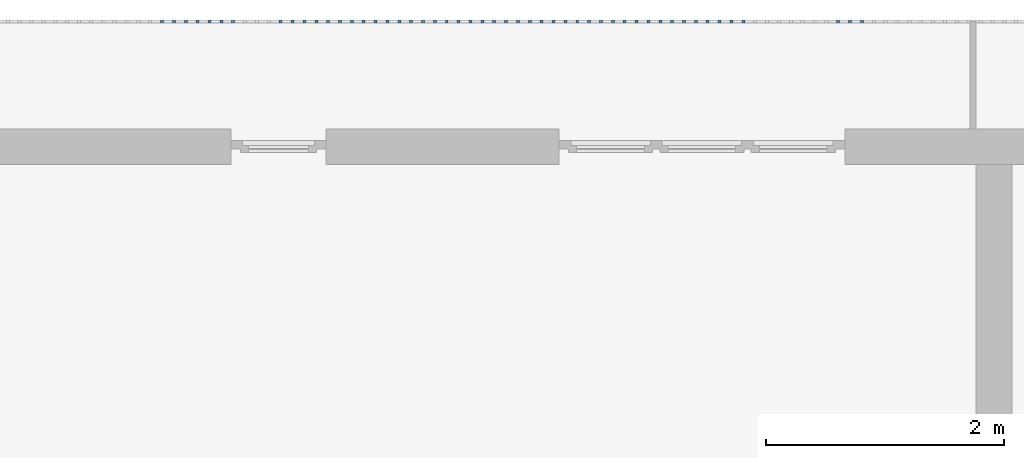
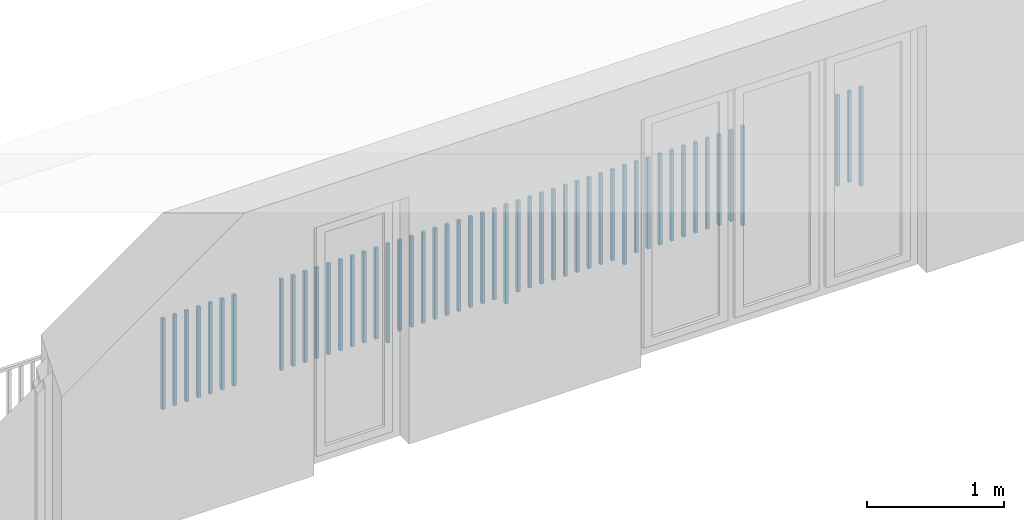
# One storey, part 43 of 48: 50 building element parts, 1 element without a shape of its own.
"""IFC4 building model written with IfcOpenShell, lengths in metres."""

from ifc_helpers import new_model, entity, si_unit, converted_unit, derived_unit, direction, frame, origin_with_axes, place, context, subcontext, project, spatial, polygons, material, type_object, element, aggregate, save


model = new_model("IFC4")

# Units and contexts
model_context = context("Model", 3, precision=1e-05, world=origin_with_axes(), true_north=direction((0.0, 1.0)))
body_context = subcontext(model_context, "Body", "Model", "MODEL_VIEW")
ifc_project = project(units=[si_unit("LENGTHUNIT", "METRE"), si_unit("AREAUNIT", "SQUARE_METRE"), si_unit("VOLUMEUNIT", "CUBIC_METRE"), converted_unit("PLANEANGLEUNIT", "DEGREE", entity("IfcPlaneAngleMeasure", 0.0174532925199), si_unit("PLANEANGLEUNIT", "RADIAN"), dimensions=[0, 0, 0, 0, 0, 0, 0]), converted_unit("TIMEUNIT", "Year", entity("IfcTimeMeasure", 31556926.0), si_unit("TIMEUNIT", "SECOND"), dimensions=[0, 0, 1, 0, 0, 0, 0]), si_unit("MASSUNIT", "GRAM", prefix="KILO"), si_unit("THERMODYNAMICTEMPERATUREUNIT", "DEGREE_CELSIUS"), si_unit("LUMINOUSINTENSITYUNIT", "LUMEN"), si_unit("ENERGYUNIT", "JOULE", prefix="MEGA"), derived_unit("THERMALCONDUCTANCEUNIT", [(si_unit("POWERUNIT", "WATT"), 1), (si_unit("LENGTHUNIT", "METRE"), -1), (si_unit("THERMODYNAMICTEMPERATUREUNIT", "KELVIN"), -1)]), derived_unit("SPECIFICHEATCAPACITYUNIT", [(si_unit("ENERGYUNIT", "JOULE"), 1), (si_unit("MASSUNIT", "GRAM", prefix="KILO"), -1), (si_unit("THERMODYNAMICTEMPERATUREUNIT", "KELVIN"), -1)]), derived_unit("MASSDENSITYUNIT", [(si_unit("MASSUNIT", "GRAM", prefix="KILO"), 1), (si_unit("VOLUMEUNIT", "CUBIC_METRE"), -1)])], contexts=[model_context])

# Site, building, storey
site_placement = place(None, origin_with_axes())
site = spatial("IfcSite", under=ifc_project, at=site_placement, CompositionType="ELEMENT")
building_placement = place(site_placement, origin_with_axes())
building = spatial("IfcBuilding", under=site, at=building_placement, CompositionType="ELEMENT")
storey_placement = place(building_placement, frame((0.0, 0.0, 3.4), z_axis=(0.0, 0.0, 1.0), x_axis=(1.0, 0.0, 0.0)))
storey = spatial("IfcBuildingStorey", under=building, at=storey_placement, Name="1. Geschoss", CompositionType="ELEMENT", Elevation=3.4)

# Railing, building element parts
railing_type = type_object("IfcRailingType", PredefinedType="NOTDEFINED")
railing_placement = place(storey_placement, frame((10.2378006196, 9.82118776896, 0.0), z_axis=(0.0, 0.0, 1.0), x_axis=(1.0, 0.0, 0.0)))
railing = element("IfcRailing", 1, at=railing_placement, inside=storey, type_object=railing_type, PredefinedType="NOTDEFINED")
ifc_material = material()
building_element_part_1_placement = place(railing_placement, origin_with_axes())
building_element_part_1 = element("IfcBuildingElementPart", 2, at=building_element_part_1_placement, material=ifc_material, PredefinedType="NOTDEFINED", context=body_context, shape_type="Tessellation", body=[
    polygons([(-11.9498913043, 0.0125, 0.0), (-11.9498913043, -0.0125, 0.0), (-11.9498913043, -0.0125, 0.88), (-11.9498913043, 0.0125, 0.88), (-11.9248913043, 0.0125, 0.0), (-11.9248913043, -0.0125, 0.0), (-11.9248913043, -0.0125, 0.88), (-11.9248913043, 0.0125, 0.88)], [[[1, 2, 3, 4]], [[1, 5, 6, 2]], [[2, 6, 7, 3]], [[4, 3, 7, 8]], [[5, 1, 4, 8]], [[6, 5, 8, 7]]], closed=True),
])
building_element_part_2_placement = place(railing_placement, origin_with_axes())
building_element_part_2 = element("IfcBuildingElementPart", 3, at=building_element_part_2_placement, material=ifc_material, PredefinedType="NOTDEFINED", context=body_context, shape_type="Tessellation", body=[
    polygons([(-12.0493695652, 0.0125, 0.07), (-12.0493695652, -0.0125, 0.07), (-12.0493695652, -0.0125, 0.8775), (-12.0493695652, 0.0125, 0.8775), (-12.0243695652, 0.0125, 0.07), (-12.0243695652, -0.0125, 0.07), (-12.0243695652, -0.0125, 0.8775), (-12.0243695652, 0.0125, 0.8775)], [[[1, 2, 3, 4]], [[1, 5, 6, 2]], [[2, 6, 7, 3]], [[4, 3, 7, 8]], [[5, 1, 4, 8]], [[6, 5, 8, 7]]], closed=True),
])
building_element_part_3_placement = place(railing_placement, origin_with_axes())
building_element_part_3 = element("IfcBuildingElementPart", 4, at=building_element_part_3_placement, material=ifc_material, PredefinedType="NOTDEFINED", context=body_context, shape_type="Tessellation", body=[
    polygons([(-12.1488478261, 0.0125, 0.07), (-12.1488478261, -0.0125, 0.07), (-12.1488478261, -0.0125, 0.8775), (-12.1488478261, 0.0125, 0.8775), (-12.1238478261, 0.0125, 0.07), (-12.1238478261, -0.0125, 0.07), (-12.1238478261, -0.0125, 0.8775), (-12.1238478261, 0.0125, 0.8775)], [[[1, 2, 3, 4]], [[1, 5, 6, 2]], [[2, 6, 7, 3]], [[4, 3, 7, 8]], [[5, 1, 4, 8]], [[6, 5, 8, 7]]], closed=True),
])
building_element_part_4_placement = place(railing_placement, origin_with_axes())
building_element_part_4 = element("IfcBuildingElementPart", 5, at=building_element_part_4_placement, material=ifc_material, PredefinedType="NOTDEFINED", context=body_context, shape_type="Tessellation", body=[
    polygons([(-12.944673913, 0.0125, 0.0), (-12.944673913, -0.0125, 0.0), (-12.944673913, -0.0125, 0.88), (-12.944673913, 0.0125, 0.88), (-12.919673913, 0.0125, 0.0), (-12.919673913, -0.0125, 0.0), (-12.919673913, -0.0125, 0.88), (-12.919673913, 0.0125, 0.88)], [[[1, 2, 3, 4]], [[1, 5, 6, 2]], [[2, 6, 7, 3]], [[4, 3, 7, 8]], [[5, 1, 4, 8]], [[6, 5, 8, 7]]], closed=True),
])
building_element_part_5_placement = place(railing_placement, origin_with_axes())
building_element_part_5 = element("IfcBuildingElementPart", 6, at=building_element_part_5_placement, material=ifc_material, PredefinedType="NOTDEFINED", context=body_context, shape_type="Tessellation", body=[
    polygons([(-13.0441521739, 0.0125, 0.07), (-13.0441521739, -0.0125, 0.07), (-13.0441521739, -0.0125, 0.8775), (-13.0441521739, 0.0125, 0.8775), (-13.0191521739, 0.0125, 0.07), (-13.0191521739, -0.0125, 0.07), (-13.0191521739, -0.0125, 0.8775), (-13.0191521739, 0.0125, 0.8775)], [[[1, 2, 3, 4]], [[1, 5, 6, 2]], [[2, 6, 7, 3]], [[4, 3, 7, 8]], [[5, 1, 4, 8]], [[6, 5, 8, 7]]], closed=True),
])
building_element_part_6_placement = place(railing_placement, origin_with_axes())
building_element_part_6 = element("IfcBuildingElementPart", 7, at=building_element_part_6_placement, material=ifc_material, PredefinedType="NOTDEFINED", context=body_context, shape_type="Tessellation", body=[
    polygons([(-13.1436304348, 0.0125, 0.07), (-13.1436304348, -0.0125, 0.07), (-13.1436304348, -0.0125, 0.8775), (-13.1436304348, 0.0125, 0.8775), (-13.1186304348, 0.0125, 0.07), (-13.1186304348, -0.0125, 0.07), (-13.1186304348, -0.0125, 0.8775), (-13.1186304348, 0.0125, 0.8775)], [[[1, 2, 3, 4]], [[1, 5, 6, 2]], [[2, 6, 7, 3]], [[4, 3, 7, 8]], [[5, 1, 4, 8]], [[6, 5, 8, 7]]], closed=True),
])
building_element_part_7_placement = place(railing_placement, origin_with_axes())
building_element_part_7 = element("IfcBuildingElementPart", 8, at=building_element_part_7_placement, material=ifc_material, PredefinedType="NOTDEFINED", context=body_context, shape_type="Tessellation", body=[
    polygons([(-13.2431086957, 0.0125, 0.07), (-13.2431086957, -0.0125, 0.07), (-13.2431086957, -0.0125, 0.8775), (-13.2431086957, 0.0125, 0.8775), (-13.2181086957, 0.0125, 0.07), (-13.2181086957, -0.0125, 0.07), (-13.2181086957, -0.0125, 0.8775), (-13.2181086957, 0.0125, 0.8775)], [[[1, 2, 3, 4]], [[1, 5, 6, 2]], [[2, 6, 7, 3]], [[4, 3, 7, 8]], [[5, 1, 4, 8]], [[6, 5, 8, 7]]], closed=True),
])
building_element_part_8_placement = place(railing_placement, origin_with_axes())
building_element_part_8 = element("IfcBuildingElementPart", 9, at=building_element_part_8_placement, material=ifc_material, PredefinedType="NOTDEFINED", context=body_context, shape_type="Tessellation", body=[
    polygons([(-13.3425869565, 0.0125, 0.07), (-13.3425869565, -0.0125, 0.07), (-13.3425869565, -0.0125, 0.8775), (-13.3425869565, 0.0125, 0.8775), (-13.3175869565, 0.0125, 0.07), (-13.3175869565, -0.0125, 0.07), (-13.3175869565, -0.0125, 0.8775), (-13.3175869565, 0.0125, 0.8775)], [[[1, 2, 3, 4]], [[1, 5, 6, 2]], [[2, 6, 7, 3]], [[4, 3, 7, 8]], [[5, 1, 4, 8]], [[6, 5, 8, 7]]], closed=True),
])
building_element_part_9_placement = place(railing_placement, origin_with_axes())
building_element_part_9 = element("IfcBuildingElementPart", 10, at=building_element_part_9_placement, material=ifc_material, PredefinedType="NOTDEFINED", context=body_context, shape_type="Tessellation", body=[
    polygons([(-13.4420652174, 0.0125, 0.07), (-13.4420652174, -0.0125, 0.07), (-13.4420652174, -0.0125, 0.8775), (-13.4420652174, 0.0125, 0.8775), (-13.4170652174, 0.0125, 0.07), (-13.4170652174, -0.0125, 0.07), (-13.4170652174, -0.0125, 0.8775), (-13.4170652174, 0.0125, 0.8775)], [[[1, 2, 3, 4]], [[1, 5, 6, 2]], [[2, 6, 7, 3]], [[4, 3, 7, 8]], [[5, 1, 4, 8]], [[6, 5, 8, 7]]], closed=True),
])
building_element_part_10_placement = place(railing_placement, origin_with_axes())
building_element_part_10 = element("IfcBuildingElementPart", 11, at=building_element_part_10_placement, material=ifc_material, PredefinedType="NOTDEFINED", context=body_context, shape_type="Tessellation", body=[
    polygons([(-13.5415434783, 0.0125, 0.07), (-13.5415434783, -0.0125, 0.07), (-13.5415434783, -0.0125, 0.8775), (-13.5415434783, 0.0125, 0.8775), (-13.5165434783, 0.0125, 0.07), (-13.5165434783, -0.0125, 0.07), (-13.5165434783, -0.0125, 0.8775), (-13.5165434783, 0.0125, 0.8775)], [[[1, 2, 3, 4]], [[1, 5, 6, 2]], [[2, 6, 7, 3]], [[4, 3, 7, 8]], [[5, 1, 4, 8]], [[6, 5, 8, 7]]], closed=True),
])
building_element_part_11_placement = place(railing_placement, origin_with_axes())
building_element_part_11 = element("IfcBuildingElementPart", 12, at=building_element_part_11_placement, material=ifc_material, PredefinedType="NOTDEFINED", context=body_context, shape_type="Tessellation", body=[
    polygons([(-13.6410217391, 0.0125, 0.07), (-13.6410217391, -0.0125, 0.07), (-13.6410217391, -0.0125, 0.8775), (-13.6410217391, 0.0125, 0.8775), (-13.6160217391, 0.0125, 0.07), (-13.6160217391, -0.0125, 0.07), (-13.6160217391, -0.0125, 0.8775), (-13.6160217391, 0.0125, 0.8775)], [[[1, 2, 3, 4]], [[1, 5, 6, 2]], [[2, 6, 7, 3]], [[4, 3, 7, 8]], [[5, 1, 4, 8]], [[6, 5, 8, 7]]], closed=True),
])
building_element_part_12_placement = place(railing_placement, origin_with_axes())
building_element_part_12 = element("IfcBuildingElementPart", 13, at=building_element_part_12_placement, material=ifc_material, PredefinedType="NOTDEFINED", context=body_context, shape_type="Tessellation", body=[
    polygons([(-13.7405, 0.0125, 0.07), (-13.7405, -0.0125, 0.07), (-13.7405, -0.0125, 0.8775), (-13.7405, 0.0125, 0.8775), (-13.7155, 0.0125, 0.07), (-13.7155, -0.0125, 0.07), (-13.7155, -0.0125, 0.8775), (-13.7155, 0.0125, 0.8775)], [[[1, 2, 3, 4]], [[1, 5, 6, 2]], [[2, 6, 7, 3]], [[4, 3, 7, 8]], [[5, 1, 4, 8]], [[6, 5, 8, 7]]], closed=True),
])
building_element_part_13_placement = place(railing_placement, origin_with_axes())
building_element_part_13 = element("IfcBuildingElementPart", 14, at=building_element_part_13_placement, material=ifc_material, PredefinedType="NOTDEFINED", context=body_context, shape_type="Tessellation", body=[
    polygons([(-13.8399782609, 0.0125, 0.07), (-13.8399782609, -0.0125, 0.07), (-13.8399782609, -0.0125, 0.8775), (-13.8399782609, 0.0125, 0.8775), (-13.8149782609, 0.0125, 0.07), (-13.8149782609, -0.0125, 0.07), (-13.8149782609, -0.0125, 0.8775), (-13.8149782609, 0.0125, 0.8775)], [[[1, 2, 3, 4]], [[1, 5, 6, 2]], [[2, 6, 7, 3]], [[4, 3, 7, 8]], [[5, 1, 4, 8]], [[6, 5, 8, 7]]], closed=True),
])
building_element_part_14_placement = place(railing_placement, origin_with_axes())
building_element_part_14 = element("IfcBuildingElementPart", 15, at=building_element_part_14_placement, material=ifc_material, PredefinedType="NOTDEFINED", context=body_context, shape_type="Tessellation", body=[
    polygons([(-13.9394565217, 0.0125, 0.0), (-13.9394565217, -0.0125, 0.0), (-13.9394565217, -0.0125, 0.88), (-13.9394565217, 0.0125, 0.88), (-13.9144565217, 0.0125, 0.0), (-13.9144565217, -0.0125, 0.0), (-13.9144565217, -0.0125, 0.88), (-13.9144565217, 0.0125, 0.88)], [[[1, 2, 3, 4]], [[1, 5, 6, 2]], [[2, 6, 7, 3]], [[4, 3, 7, 8]], [[5, 1, 4, 8]], [[6, 5, 8, 7]]], closed=True),
])
building_element_part_15_placement = place(railing_placement, origin_with_axes())
building_element_part_15 = element("IfcBuildingElementPart", 16, at=building_element_part_15_placement, material=ifc_material, PredefinedType="NOTDEFINED", context=body_context, shape_type="Tessellation", body=[
    polygons([(-14.0389347826, 0.0125, 0.07), (-14.0389347826, -0.0125, 0.07), (-14.0389347826, -0.0125, 0.8775), (-14.0389347826, 0.0125, 0.8775), (-14.0139347826, 0.0125, 0.07), (-14.0139347826, -0.0125, 0.07), (-14.0139347826, -0.0125, 0.8775), (-14.0139347826, 0.0125, 0.8775)], [[[1, 2, 3, 4]], [[1, 5, 6, 2]], [[2, 6, 7, 3]], [[4, 3, 7, 8]], [[5, 1, 4, 8]], [[6, 5, 8, 7]]], closed=True),
])
building_element_part_16_placement = place(railing_placement, origin_with_axes())
building_element_part_16 = element("IfcBuildingElementPart", 17, at=building_element_part_16_placement, material=ifc_material, PredefinedType="NOTDEFINED", context=body_context, shape_type="Tessellation", body=[
    polygons([(-14.1384130435, 0.0125, 0.07), (-14.1384130435, -0.0125, 0.07), (-14.1384130435, -0.0125, 0.8775), (-14.1384130435, 0.0125, 0.8775), (-14.1134130435, 0.0125, 0.07), (-14.1134130435, -0.0125, 0.07), (-14.1134130435, -0.0125, 0.8775), (-14.1134130435, 0.0125, 0.8775)], [[[1, 2, 3, 4]], [[1, 5, 6, 2]], [[2, 6, 7, 3]], [[4, 3, 7, 8]], [[5, 1, 4, 8]], [[6, 5, 8, 7]]], closed=True),
])
building_element_part_17_placement = place(railing_placement, origin_with_axes())
building_element_part_17 = element("IfcBuildingElementPart", 18, at=building_element_part_17_placement, material=ifc_material, PredefinedType="NOTDEFINED", context=body_context, shape_type="Tessellation", body=[
    polygons([(-14.2378913043, 0.0125, 0.07), (-14.2378913043, -0.0125, 0.07), (-14.2378913043, -0.0125, 0.8775), (-14.2378913043, 0.0125, 0.8775), (-14.2128913043, 0.0125, 0.07), (-14.2128913043, -0.0125, 0.07), (-14.2128913043, -0.0125, 0.8775), (-14.2128913043, 0.0125, 0.8775)], [[[1, 2, 3, 4]], [[1, 5, 6, 2]], [[2, 6, 7, 3]], [[4, 3, 7, 8]], [[5, 1, 4, 8]], [[6, 5, 8, 7]]], closed=True),
])
building_element_part_18_placement = place(railing_placement, origin_with_axes())
building_element_part_18 = element("IfcBuildingElementPart", 19, at=building_element_part_18_placement, material=ifc_material, PredefinedType="NOTDEFINED", context=body_context, shape_type="Tessellation", body=[
    polygons([(-14.3373695652, 0.0125, 0.07), (-14.3373695652, -0.0125, 0.07), (-14.3373695652, -0.0125, 0.8775), (-14.3373695652, 0.0125, 0.8775), (-14.3123695652, 0.0125, 0.07), (-14.3123695652, -0.0125, 0.07), (-14.3123695652, -0.0125, 0.8775), (-14.3123695652, 0.0125, 0.8775)], [[[1, 2, 3, 4]], [[1, 5, 6, 2]], [[2, 6, 7, 3]], [[4, 3, 7, 8]], [[5, 1, 4, 8]], [[6, 5, 8, 7]]], closed=True),
])
building_element_part_19_placement = place(railing_placement, origin_with_axes())
building_element_part_19 = element("IfcBuildingElementPart", 20, at=building_element_part_19_placement, material=ifc_material, PredefinedType="NOTDEFINED", context=body_context, shape_type="Tessellation", body=[
    polygons([(-14.4368478261, 0.0125, 0.07), (-14.4368478261, -0.0125, 0.07), (-14.4368478261, -0.0125, 0.8775), (-14.4368478261, 0.0125, 0.8775), (-14.4118478261, 0.0125, 0.07), (-14.4118478261, -0.0125, 0.07), (-14.4118478261, -0.0125, 0.8775), (-14.4118478261, 0.0125, 0.8775)], [[[1, 2, 3, 4]], [[1, 5, 6, 2]], [[2, 6, 7, 3]], [[4, 3, 7, 8]], [[5, 1, 4, 8]], [[6, 5, 8, 7]]], closed=True),
])
building_element_part_20_placement = place(railing_placement, origin_with_axes())
building_element_part_20 = element("IfcBuildingElementPart", 21, at=building_element_part_20_placement, material=ifc_material, PredefinedType="NOTDEFINED", context=body_context, shape_type="Tessellation", body=[
    polygons([(-14.536326087, 0.0125, 0.07), (-14.536326087, -0.0125, 0.07), (-14.536326087, -0.0125, 0.8775), (-14.536326087, 0.0125, 0.8775), (-14.511326087, 0.0125, 0.07), (-14.511326087, -0.0125, 0.07), (-14.511326087, -0.0125, 0.8775), (-14.511326087, 0.0125, 0.8775)], [[[1, 2, 3, 4]], [[1, 5, 6, 2]], [[2, 6, 7, 3]], [[4, 3, 7, 8]], [[5, 1, 4, 8]], [[6, 5, 8, 7]]], closed=True),
])
building_element_part_21_placement = place(railing_placement, origin_with_axes())
building_element_part_21 = element("IfcBuildingElementPart", 22, at=building_element_part_21_placement, material=ifc_material, PredefinedType="NOTDEFINED", context=body_context, shape_type="Tessellation", body=[
    polygons([(-14.6358043478, 0.0125, 0.07), (-14.6358043478, -0.0125, 0.07), (-14.6358043478, -0.0125, 0.8775), (-14.6358043478, 0.0125, 0.8775), (-14.6108043478, 0.0125, 0.07), (-14.6108043478, -0.0125, 0.07), (-14.6108043478, -0.0125, 0.8775), (-14.6108043478, 0.0125, 0.8775)], [[[1, 2, 3, 4]], [[1, 5, 6, 2]], [[2, 6, 7, 3]], [[4, 3, 7, 8]], [[5, 1, 4, 8]], [[6, 5, 8, 7]]], closed=True),
])
building_element_part_22_placement = place(railing_placement, origin_with_axes())
building_element_part_22 = element("IfcBuildingElementPart", 23, at=building_element_part_22_placement, material=ifc_material, PredefinedType="NOTDEFINED", context=body_context, shape_type="Tessellation", body=[
    polygons([(-14.7352826087, 0.0125, 0.07), (-14.7352826087, -0.0125, 0.07), (-14.7352826087, -0.0125, 0.8775), (-14.7352826087, 0.0125, 0.8775), (-14.7102826087, 0.0125, 0.07), (-14.7102826087, -0.0125, 0.07), (-14.7102826087, -0.0125, 0.8775), (-14.7102826087, 0.0125, 0.8775)], [[[1, 2, 3, 4]], [[1, 5, 6, 2]], [[2, 6, 7, 3]], [[4, 3, 7, 8]], [[5, 1, 4, 8]], [[6, 5, 8, 7]]], closed=True),
])
building_element_part_23_placement = place(railing_placement, origin_with_axes())
building_element_part_23 = element("IfcBuildingElementPart", 24, at=building_element_part_23_placement, material=ifc_material, PredefinedType="NOTDEFINED", context=body_context, shape_type="Tessellation", body=[
    polygons([(-14.8347608696, 0.0125, 0.07), (-14.8347608696, -0.0125, 0.07), (-14.8347608696, -0.0125, 0.8775), (-14.8347608696, 0.0125, 0.8775), (-14.8097608696, 0.0125, 0.07), (-14.8097608696, -0.0125, 0.07), (-14.8097608696, -0.0125, 0.8775), (-14.8097608696, 0.0125, 0.8775)], [[[1, 2, 3, 4]], [[1, 5, 6, 2]], [[2, 6, 7, 3]], [[4, 3, 7, 8]], [[5, 1, 4, 8]], [[6, 5, 8, 7]]], closed=True),
])
building_element_part_24_placement = place(railing_placement, origin_with_axes())
building_element_part_24 = element("IfcBuildingElementPart", 25, at=building_element_part_24_placement, material=ifc_material, PredefinedType="NOTDEFINED", context=body_context, shape_type="Tessellation", body=[
    polygons([(-14.9342391304, 0.0125, 0.0), (-14.9342391304, -0.0125, 0.0), (-14.9342391304, -0.0125, 0.88), (-14.9342391304, 0.0125, 0.88), (-14.9092391304, 0.0125, 0.0), (-14.9092391304, -0.0125, 0.0), (-14.9092391304, -0.0125, 0.88), (-14.9092391304, 0.0125, 0.88)], [[[1, 2, 3, 4]], [[1, 5, 6, 2]], [[2, 6, 7, 3]], [[4, 3, 7, 8]], [[5, 1, 4, 8]], [[6, 5, 8, 7]]], closed=True),
])
building_element_part_25_placement = place(railing_placement, origin_with_axes())
building_element_part_25 = element("IfcBuildingElementPart", 26, at=building_element_part_25_placement, material=ifc_material, PredefinedType="NOTDEFINED", context=body_context, shape_type="Tessellation", body=[
    polygons([(-15.0337173913, 0.0125, 0.07), (-15.0337173913, -0.0125, 0.07), (-15.0337173913, -0.0125, 0.8775), (-15.0337173913, 0.0125, 0.8775), (-15.0087173913, 0.0125, 0.07), (-15.0087173913, -0.0125, 0.07), (-15.0087173913, -0.0125, 0.8775), (-15.0087173913, 0.0125, 0.8775)], [[[1, 2, 3, 4]], [[1, 5, 6, 2]], [[2, 6, 7, 3]], [[4, 3, 7, 8]], [[5, 1, 4, 8]], [[6, 5, 8, 7]]], closed=True),
])
building_element_part_26_placement = place(railing_placement, origin_with_axes())
building_element_part_26 = element("IfcBuildingElementPart", 27, at=building_element_part_26_placement, material=ifc_material, PredefinedType="NOTDEFINED", context=body_context, shape_type="Tessellation", body=[
    polygons([(-15.1331956522, 0.0125, 0.07), (-15.1331956522, -0.0125, 0.07), (-15.1331956522, -0.0125, 0.8775), (-15.1331956522, 0.0125, 0.8775), (-15.1081956522, 0.0125, 0.07), (-15.1081956522, -0.0125, 0.07), (-15.1081956522, -0.0125, 0.8775), (-15.1081956522, 0.0125, 0.8775)], [[[1, 2, 3, 4]], [[1, 5, 6, 2]], [[2, 6, 7, 3]], [[4, 3, 7, 8]], [[5, 1, 4, 8]], [[6, 5, 8, 7]]], closed=True),
])
building_element_part_27_placement = place(railing_placement, origin_with_axes())
building_element_part_27 = element("IfcBuildingElementPart", 28, at=building_element_part_27_placement, material=ifc_material, PredefinedType="NOTDEFINED", context=body_context, shape_type="Tessellation", body=[
    polygons([(-15.232673913, 0.0125, 0.07), (-15.232673913, -0.0125, 0.07), (-15.232673913, -0.0125, 0.8775), (-15.232673913, 0.0125, 0.8775), (-15.207673913, 0.0125, 0.07), (-15.207673913, -0.0125, 0.07), (-15.207673913, -0.0125, 0.8775), (-15.207673913, 0.0125, 0.8775)], [[[1, 2, 3, 4]], [[1, 5, 6, 2]], [[2, 6, 7, 3]], [[4, 3, 7, 8]], [[5, 1, 4, 8]], [[6, 5, 8, 7]]], closed=True),
])
building_element_part_28_placement = place(railing_placement, origin_with_axes())
building_element_part_28 = element("IfcBuildingElementPart", 29, at=building_element_part_28_placement, material=ifc_material, PredefinedType="NOTDEFINED", context=body_context, shape_type="Tessellation", body=[
    polygons([(-15.3321521739, 0.0125, 0.07), (-15.3321521739, -0.0125, 0.07), (-15.3321521739, -0.0125, 0.8775), (-15.3321521739, 0.0125, 0.8775), (-15.3071521739, 0.0125, 0.07), (-15.3071521739, -0.0125, 0.07), (-15.3071521739, -0.0125, 0.8775), (-15.3071521739, 0.0125, 0.8775)], [[[1, 2, 3, 4]], [[1, 5, 6, 2]], [[2, 6, 7, 3]], [[4, 3, 7, 8]], [[5, 1, 4, 8]], [[6, 5, 8, 7]]], closed=True),
])
building_element_part_29_placement = place(railing_placement, origin_with_axes())
building_element_part_29 = element("IfcBuildingElementPart", 30, at=building_element_part_29_placement, material=ifc_material, PredefinedType="NOTDEFINED", context=body_context, shape_type="Tessellation", body=[
    polygons([(-15.4316304348, 0.0125, 0.07), (-15.4316304348, -0.0125, 0.07), (-15.4316304348, -0.0125, 0.8775), (-15.4316304348, 0.0125, 0.8775), (-15.4066304348, 0.0125, 0.07), (-15.4066304348, -0.0125, 0.07), (-15.4066304348, -0.0125, 0.8775), (-15.4066304348, 0.0125, 0.8775)], [[[1, 2, 3, 4]], [[1, 5, 6, 2]], [[2, 6, 7, 3]], [[4, 3, 7, 8]], [[5, 1, 4, 8]], [[6, 5, 8, 7]]], closed=True),
])
building_element_part_30_placement = place(railing_placement, origin_with_axes())
building_element_part_30 = element("IfcBuildingElementPart", 31, at=building_element_part_30_placement, material=ifc_material, PredefinedType="NOTDEFINED", context=body_context, shape_type="Tessellation", body=[
    polygons([(-15.5311086957, 0.0125, 0.07), (-15.5311086957, -0.0125, 0.07), (-15.5311086957, -0.0125, 0.8775), (-15.5311086957, 0.0125, 0.8775), (-15.5061086957, 0.0125, 0.07), (-15.5061086957, -0.0125, 0.07), (-15.5061086957, -0.0125, 0.8775), (-15.5061086957, 0.0125, 0.8775)], [[[1, 2, 3, 4]], [[1, 5, 6, 2]], [[2, 6, 7, 3]], [[4, 3, 7, 8]], [[5, 1, 4, 8]], [[6, 5, 8, 7]]], closed=True),
])
building_element_part_31_placement = place(railing_placement, origin_with_axes())
building_element_part_31 = element("IfcBuildingElementPart", 32, at=building_element_part_31_placement, material=ifc_material, PredefinedType="NOTDEFINED", context=body_context, shape_type="Tessellation", body=[
    polygons([(-15.6305869565, 0.0125, 0.07), (-15.6305869565, -0.0125, 0.07), (-15.6305869565, -0.0125, 0.8775), (-15.6305869565, 0.0125, 0.8775), (-15.6055869565, 0.0125, 0.07), (-15.6055869565, -0.0125, 0.07), (-15.6055869565, -0.0125, 0.8775), (-15.6055869565, 0.0125, 0.8775)], [[[1, 2, 3, 4]], [[1, 5, 6, 2]], [[2, 6, 7, 3]], [[4, 3, 7, 8]], [[5, 1, 4, 8]], [[6, 5, 8, 7]]], closed=True),
])
building_element_part_32_placement = place(railing_placement, origin_with_axes())
building_element_part_32 = element("IfcBuildingElementPart", 33, at=building_element_part_32_placement, material=ifc_material, PredefinedType="NOTDEFINED", context=body_context, shape_type="Tessellation", body=[
    polygons([(-15.7300652174, 0.0125, 0.07), (-15.7300652174, -0.0125, 0.07), (-15.7300652174, -0.0125, 0.8775), (-15.7300652174, 0.0125, 0.8775), (-15.7050652174, 0.0125, 0.07), (-15.7050652174, -0.0125, 0.07), (-15.7050652174, -0.0125, 0.8775), (-15.7050652174, 0.0125, 0.8775)], [[[1, 2, 3, 4]], [[1, 5, 6, 2]], [[2, 6, 7, 3]], [[4, 3, 7, 8]], [[5, 1, 4, 8]], [[6, 5, 8, 7]]], closed=True),
])
building_element_part_33_placement = place(railing_placement, origin_with_axes())
building_element_part_33 = element("IfcBuildingElementPart", 34, at=building_element_part_33_placement, material=ifc_material, PredefinedType="NOTDEFINED", context=body_context, shape_type="Tessellation", body=[
    polygons([(-15.8295434783, 0.0125, 0.07), (-15.8295434783, -0.0125, 0.07), (-15.8295434783, -0.0125, 0.8775), (-15.8295434783, 0.0125, 0.8775), (-15.8045434783, 0.0125, 0.07), (-15.8045434783, -0.0125, 0.07), (-15.8045434783, -0.0125, 0.8775), (-15.8045434783, 0.0125, 0.8775)], [[[1, 2, 3, 4]], [[1, 5, 6, 2]], [[2, 6, 7, 3]], [[4, 3, 7, 8]], [[5, 1, 4, 8]], [[6, 5, 8, 7]]], closed=True),
])
building_element_part_34_placement = place(railing_placement, origin_with_axes())
building_element_part_34 = element("IfcBuildingElementPart", 35, at=building_element_part_34_placement, material=ifc_material, PredefinedType="NOTDEFINED", context=body_context, shape_type="Tessellation", body=[
    polygons([(-15.9290217391, 0.0125, 0.0), (-15.9290217391, -0.0125, 0.0), (-15.9290217391, -0.0125, 0.88), (-15.9290217391, 0.0125, 0.88), (-15.9040217391, 0.0125, 0.0), (-15.9040217391, -0.0125, 0.0), (-15.9040217391, -0.0125, 0.88), (-15.9040217391, 0.0125, 0.88)], [[[1, 2, 3, 4]], [[1, 5, 6, 2]], [[2, 6, 7, 3]], [[4, 3, 7, 8]], [[5, 1, 4, 8]], [[6, 5, 8, 7]]], closed=True),
])
building_element_part_35_placement = place(railing_placement, origin_with_axes())
building_element_part_35 = element("IfcBuildingElementPart", 36, at=building_element_part_35_placement, material=ifc_material, PredefinedType="NOTDEFINED", context=body_context, shape_type="Tessellation", body=[
    polygons([(-16.0285, 0.0125, 0.07), (-16.0285, -0.0125, 0.07), (-16.0285, -0.0125, 0.8775), (-16.0285, 0.0125, 0.8775), (-16.0035, 0.0125, 0.07), (-16.0035, -0.0125, 0.07), (-16.0035, -0.0125, 0.8775), (-16.0035, 0.0125, 0.8775)], [[[1, 2, 3, 4]], [[1, 5, 6, 2]], [[2, 6, 7, 3]], [[4, 3, 7, 8]], [[5, 1, 4, 8]], [[6, 5, 8, 7]]], closed=True),
])
building_element_part_36_placement = place(railing_placement, origin_with_axes())
building_element_part_36 = element("IfcBuildingElementPart", 37, at=building_element_part_36_placement, material=ifc_material, PredefinedType="NOTDEFINED", context=body_context, shape_type="Tessellation", body=[
    polygons([(-16.1279782609, 0.0125, 0.07), (-16.1279782609, -0.0125, 0.07), (-16.1279782609, -0.0125, 0.8775), (-16.1279782609, 0.0125, 0.8775), (-16.1029782609, 0.0125, 0.07), (-16.1029782609, -0.0125, 0.07), (-16.1029782609, -0.0125, 0.8775), (-16.1029782609, 0.0125, 0.8775)], [[[1, 2, 3, 4]], [[1, 5, 6, 2]], [[2, 6, 7, 3]], [[4, 3, 7, 8]], [[5, 1, 4, 8]], [[6, 5, 8, 7]]], closed=True),
])
building_element_part_37_placement = place(railing_placement, origin_with_axes())
building_element_part_37 = element("IfcBuildingElementPart", 38, at=building_element_part_37_placement, material=ifc_material, PredefinedType="NOTDEFINED", context=body_context, shape_type="Tessellation", body=[
    polygons([(-16.2274565217, 0.0125, 0.07), (-16.2274565217, -0.0125, 0.07), (-16.2274565217, -0.0125, 0.8775), (-16.2274565217, 0.0125, 0.8775), (-16.2024565217, 0.0125, 0.07), (-16.2024565217, -0.0125, 0.07), (-16.2024565217, -0.0125, 0.8775), (-16.2024565217, 0.0125, 0.8775)], [[[1, 2, 3, 4]], [[1, 5, 6, 2]], [[2, 6, 7, 3]], [[4, 3, 7, 8]], [[5, 1, 4, 8]], [[6, 5, 8, 7]]], closed=True),
])
building_element_part_38_placement = place(railing_placement, origin_with_axes())
building_element_part_38 = element("IfcBuildingElementPart", 39, at=building_element_part_38_placement, material=ifc_material, PredefinedType="NOTDEFINED", context=body_context, shape_type="Tessellation", body=[
    polygons([(-16.3269347826, 0.0125, 0.07), (-16.3269347826, -0.0125, 0.07), (-16.3269347826, -0.0125, 0.8775), (-16.3269347826, 0.0125, 0.8775), (-16.3019347826, 0.0125, 0.07), (-16.3019347826, -0.0125, 0.07), (-16.3019347826, -0.0125, 0.8775), (-16.3019347826, 0.0125, 0.8775)], [[[1, 2, 3, 4]], [[1, 5, 6, 2]], [[2, 6, 7, 3]], [[4, 3, 7, 8]], [[5, 1, 4, 8]], [[6, 5, 8, 7]]], closed=True),
])
building_element_part_39_placement = place(railing_placement, origin_with_axes())
building_element_part_39 = element("IfcBuildingElementPart", 40, at=building_element_part_39_placement, material=ifc_material, PredefinedType="NOTDEFINED", context=body_context, shape_type="Tessellation", body=[
    polygons([(-16.4264130435, 0.0125, 0.07), (-16.4264130435, -0.0125, 0.07), (-16.4264130435, -0.0125, 0.8775), (-16.4264130435, 0.0125, 0.8775), (-16.4014130435, 0.0125, 0.07), (-16.4014130435, -0.0125, 0.07), (-16.4014130435, -0.0125, 0.8775), (-16.4014130435, 0.0125, 0.8775)], [[[1, 2, 3, 4]], [[1, 5, 6, 2]], [[2, 6, 7, 3]], [[4, 3, 7, 8]], [[5, 1, 4, 8]], [[6, 5, 8, 7]]], closed=True),
])
building_element_part_40_placement = place(railing_placement, origin_with_axes())
building_element_part_40 = element("IfcBuildingElementPart", 41, at=building_element_part_40_placement, material=ifc_material, PredefinedType="NOTDEFINED", context=body_context, shape_type="Tessellation", body=[
    polygons([(-16.5258913043, 0.0125, 0.07), (-16.5258913043, -0.0125, 0.07), (-16.5258913043, -0.0125, 0.8775), (-16.5258913043, 0.0125, 0.8775), (-16.5008913043, 0.0125, 0.07), (-16.5008913043, -0.0125, 0.07), (-16.5008913043, -0.0125, 0.8775), (-16.5008913043, 0.0125, 0.8775)], [[[1, 2, 3, 4]], [[1, 5, 6, 2]], [[2, 6, 7, 3]], [[4, 3, 7, 8]], [[5, 1, 4, 8]], [[6, 5, 8, 7]]], closed=True),
])
building_element_part_41_placement = place(railing_placement, origin_with_axes())
building_element_part_41 = element("IfcBuildingElementPart", 42, at=building_element_part_41_placement, material=ifc_material, PredefinedType="NOTDEFINED", context=body_context, shape_type="Tessellation", body=[
    polygons([(-16.6253695652, 0.0125, 0.07), (-16.6253695652, -0.0125, 0.07), (-16.6253695652, -0.0125, 0.8775), (-16.6253695652, 0.0125, 0.8775), (-16.6003695652, 0.0125, 0.07), (-16.6003695652, -0.0125, 0.07), (-16.6003695652, -0.0125, 0.8775), (-16.6003695652, 0.0125, 0.8775)], [[[1, 2, 3, 4]], [[1, 5, 6, 2]], [[2, 6, 7, 3]], [[4, 3, 7, 8]], [[5, 1, 4, 8]], [[6, 5, 8, 7]]], closed=True),
])
building_element_part_42_placement = place(railing_placement, origin_with_axes())
building_element_part_42 = element("IfcBuildingElementPart", 43, at=building_element_part_42_placement, material=ifc_material, PredefinedType="NOTDEFINED", context=body_context, shape_type="Tessellation", body=[
    polygons([(-16.7248478261, 0.0125, 0.07), (-16.7248478261, -0.0125, 0.07), (-16.7248478261, -0.0125, 0.8775), (-16.7248478261, 0.0125, 0.8775), (-16.6998478261, 0.0125, 0.07), (-16.6998478261, -0.0125, 0.07), (-16.6998478261, -0.0125, 0.8775), (-16.6998478261, 0.0125, 0.8775)], [[[1, 2, 3, 4]], [[1, 5, 6, 2]], [[2, 6, 7, 3]], [[4, 3, 7, 8]], [[5, 1, 4, 8]], [[6, 5, 8, 7]]], closed=True),
])
building_element_part_43_placement = place(railing_placement, origin_with_axes())
building_element_part_43 = element("IfcBuildingElementPart", 44, at=building_element_part_43_placement, material=ifc_material, PredefinedType="NOTDEFINED", context=body_context, shape_type="Tessellation", body=[
    polygons([(-16.824326087, 0.0125, 0.07), (-16.824326087, -0.0125, 0.07), (-16.824326087, -0.0125, 0.8775), (-16.824326087, 0.0125, 0.8775), (-16.799326087, 0.0125, 0.07), (-16.799326087, -0.0125, 0.07), (-16.799326087, -0.0125, 0.8775), (-16.799326087, 0.0125, 0.8775)], [[[1, 2, 3, 4]], [[1, 5, 6, 2]], [[2, 6, 7, 3]], [[4, 3, 7, 8]], [[5, 1, 4, 8]], [[6, 5, 8, 7]]], closed=True),
])
building_element_part_44_placement = place(railing_placement, origin_with_axes())
building_element_part_44 = element("IfcBuildingElementPart", 45, at=building_element_part_44_placement, material=ifc_material, PredefinedType="NOTDEFINED", context=body_context, shape_type="Tessellation", body=[
    polygons([(-17.2222391304, 0.0125, 0.07), (-17.2222391304, -0.0125, 0.07), (-17.2222391304, -0.0125, 0.8775), (-17.2222391304, 0.0125, 0.8775), (-17.1972391304, 0.0125, 0.07), (-17.1972391304, -0.0125, 0.07), (-17.1972391304, -0.0125, 0.8775), (-17.1972391304, 0.0125, 0.8775)], [[[1, 2, 3, 4]], [[1, 5, 6, 2]], [[2, 6, 7, 3]], [[4, 3, 7, 8]], [[5, 1, 4, 8]], [[6, 5, 8, 7]]], closed=True),
])
building_element_part_45_placement = place(railing_placement, origin_with_axes())
building_element_part_45 = element("IfcBuildingElementPart", 46, at=building_element_part_45_placement, material=ifc_material, PredefinedType="NOTDEFINED", context=body_context, shape_type="Tessellation", body=[
    polygons([(-17.3217173913, 0.0125, 0.07), (-17.3217173913, -0.0125, 0.07), (-17.3217173913, -0.0125, 0.8775), (-17.3217173913, 0.0125, 0.8775), (-17.2967173913, 0.0125, 0.07), (-17.2967173913, -0.0125, 0.07), (-17.2967173913, -0.0125, 0.8775), (-17.2967173913, 0.0125, 0.8775)], [[[1, 2, 3, 4]], [[1, 5, 6, 2]], [[2, 6, 7, 3]], [[4, 3, 7, 8]], [[5, 1, 4, 8]], [[6, 5, 8, 7]]], closed=True),
])
building_element_part_46_placement = place(railing_placement, origin_with_axes())
building_element_part_46 = element("IfcBuildingElementPart", 47, at=building_element_part_46_placement, material=ifc_material, PredefinedType="NOTDEFINED", context=body_context, shape_type="Tessellation", body=[
    polygons([(-17.4211956522, 0.0125, 0.07), (-17.4211956522, -0.0125, 0.07), (-17.4211956522, -0.0125, 0.8775), (-17.4211956522, 0.0125, 0.8775), (-17.3961956522, 0.0125, 0.07), (-17.3961956522, -0.0125, 0.07), (-17.3961956522, -0.0125, 0.8775), (-17.3961956522, 0.0125, 0.8775)], [[[1, 2, 3, 4]], [[1, 5, 6, 2]], [[2, 6, 7, 3]], [[4, 3, 7, 8]], [[5, 1, 4, 8]], [[6, 5, 8, 7]]], closed=True),
])
building_element_part_47_placement = place(railing_placement, origin_with_axes())
building_element_part_47 = element("IfcBuildingElementPart", 48, at=building_element_part_47_placement, material=ifc_material, PredefinedType="NOTDEFINED", context=body_context, shape_type="Tessellation", body=[
    polygons([(-17.520673913, 0.0125, 0.07), (-17.520673913, -0.0125, 0.07), (-17.520673913, -0.0125, 0.8775), (-17.520673913, 0.0125, 0.8775), (-17.495673913, 0.0125, 0.07), (-17.495673913, -0.0125, 0.07), (-17.495673913, -0.0125, 0.8775), (-17.495673913, 0.0125, 0.8775)], [[[1, 2, 3, 4]], [[1, 5, 6, 2]], [[2, 6, 7, 3]], [[4, 3, 7, 8]], [[5, 1, 4, 8]], [[6, 5, 8, 7]]], closed=True),
])
building_element_part_48_placement = place(railing_placement, origin_with_axes())
building_element_part_48 = element("IfcBuildingElementPart", 49, at=building_element_part_48_placement, material=ifc_material, PredefinedType="NOTDEFINED", context=body_context, shape_type="Tessellation", body=[
    polygons([(-17.6201521739, 0.0125, 0.07), (-17.6201521739, -0.0125, 0.07), (-17.6201521739, -0.0125, 0.8775), (-17.6201521739, 0.0125, 0.8775), (-17.5951521739, 0.0125, 0.07), (-17.5951521739, -0.0125, 0.07), (-17.5951521739, -0.0125, 0.8775), (-17.5951521739, 0.0125, 0.8775)], [[[1, 2, 3, 4]], [[1, 5, 6, 2]], [[2, 6, 7, 3]], [[4, 3, 7, 8]], [[5, 1, 4, 8]], [[6, 5, 8, 7]]], closed=True),
])
building_element_part_49_placement = place(railing_placement, origin_with_axes())
building_element_part_49 = element("IfcBuildingElementPart", 50, at=building_element_part_49_placement, material=ifc_material, PredefinedType="NOTDEFINED", context=body_context, shape_type="Tessellation", body=[
    polygons([(-17.7196304348, 0.0125, 0.07), (-17.7196304348, -0.0125, 0.07), (-17.7196304348, -0.0125, 0.8775), (-17.7196304348, 0.0125, 0.8775), (-17.6946304348, 0.0125, 0.07), (-17.6946304348, -0.0125, 0.07), (-17.6946304348, -0.0125, 0.8775), (-17.6946304348, 0.0125, 0.8775)], [[[1, 2, 3, 4]], [[1, 5, 6, 2]], [[2, 6, 7, 3]], [[4, 3, 7, 8]], [[5, 1, 4, 8]], [[6, 5, 8, 7]]], closed=True),
])
building_element_part_50_placement = place(railing_placement, origin_with_axes())
building_element_part_50 = element("IfcBuildingElementPart", 51, at=building_element_part_50_placement, material=ifc_material, PredefinedType="NOTDEFINED", context=body_context, shape_type="Tessellation", body=[
    polygons([(-17.8191086957, 0.0125, 0.07), (-17.8191086957, -0.0125, 0.07), (-17.8191086957, -0.0125, 0.8775), (-17.8191086957, 0.0125, 0.8775), (-17.7941086957, 0.0125, 0.07), (-17.7941086957, -0.0125, 0.07), (-17.7941086957, -0.0125, 0.8775), (-17.7941086957, 0.0125, 0.8775)], [[[1, 2, 3, 4]], [[1, 5, 6, 2]], [[2, 6, 7, 3]], [[4, 3, 7, 8]], [[5, 1, 4, 8]], [[6, 5, 8, 7]]], closed=True),
])
aggregate(railing, [building_element_part_1, building_element_part_2, building_element_part_3, building_element_part_4, building_element_part_5, building_element_part_6, building_element_part_7, building_element_part_8, building_element_part_9, building_element_part_10, building_element_part_11, building_element_part_12, building_element_part_13, building_element_part_14, building_element_part_15, building_element_part_16, building_element_part_17, building_element_part_18, building_element_part_19, building_element_part_20, building_element_part_21, building_element_part_22, building_element_part_23, building_element_part_24, building_element_part_25, building_element_part_26, building_element_part_27, building_element_part_28, building_element_part_29, building_element_part_30, building_element_part_31, building_element_part_32, building_element_part_33, building_element_part_34, building_element_part_35, building_element_part_36, building_element_part_37, building_element_part_38, building_element_part_39, building_element_part_40, building_element_part_41, building_element_part_42, building_element_part_43, building_element_part_44, building_element_part_45, building_element_part_46, building_element_part_47, building_element_part_48, building_element_part_49, building_element_part_50])

save(model, "model.ifc")
